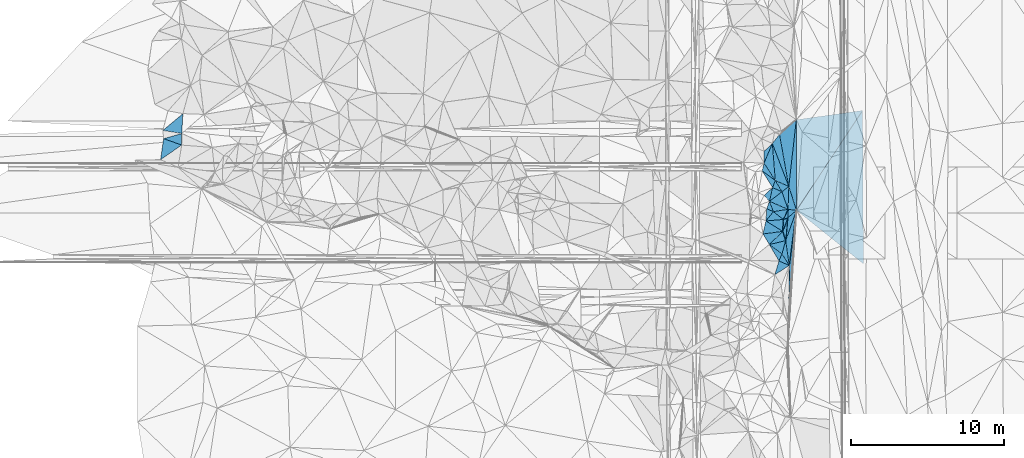
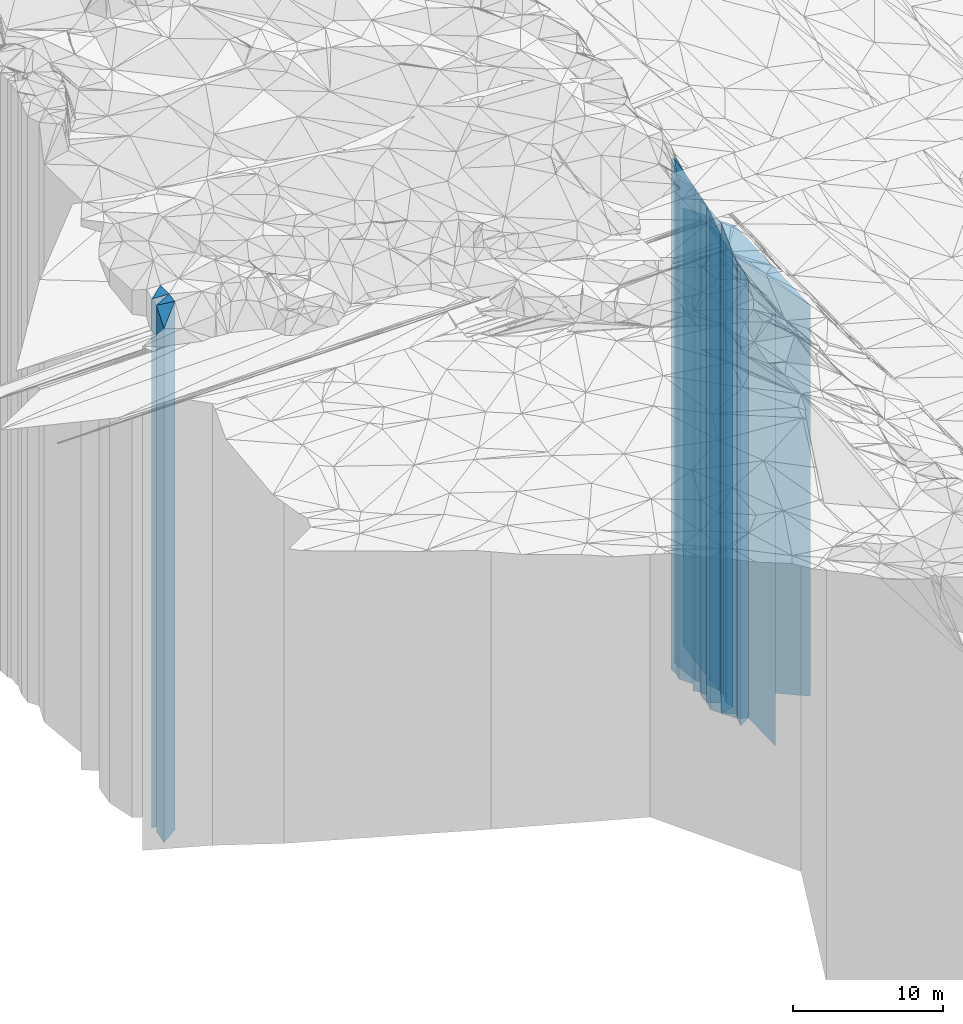
# One storey, part 214 of 275: 41 plates.
"""IFC2X3 building model written with IfcOpenShell, lengths in millimetres."""

import ifcopenshell
import ifcopenshell.guid

model = None  # the IFC model being written
_history = None  # IfcOwnerHistory: only IFC2X3 demands one
_inside = {}  # id of a spatial element -> (the spatial element, [elements in it])
_under = {}  # id of a project, library or spatial element -> (it, [spatial elements below it])
_declared = {}  # id of a project -> (the project, [libraries it declares])
_typed = {}  # id of a type object -> (the type object, [elements of that type])
_made_of = {}  # id of a material, layer set ... -> (it, [elements and type objects made of it])


def new_model(schema):
    """Start an empty IFC model of exactly this schema.

    Asked for "IFC4X3", IfcOpenShell would pick the latest addendum, in which some entities
    have other attributes; the version numbers below select the first issue.
    IFC2X3 requires an IfcOwnerHistory on every rooted entity: one is made here for all.
    """
    global model, _history
    if schema == "IFC4X3":
        model = ifcopenshell.file(schema_version=(4, 3, 0, 0))
    else:
        model = ifcopenshell.file(schema=schema)
    _inside.clear()
    _under.clear()
    _declared.clear()
    _typed.clear()
    _made_of.clear()
    _history = None
    if model.schema == "IFC2X3":
        org = make("IfcOrganization", Name="unknown")
        user = make(
            "IfcPersonAndOrganization",
            ThePerson=make("IfcPerson", FamilyName="unknown"),
            TheOrganization=org,
        )
        app = make(
            "IfcApplication",
            ApplicationDeveloper=org,
            Version="unknown",
            ApplicationFullName="unknown",
            ApplicationIdentifier="unknown",
        )
        _history = make(
            "IfcOwnerHistory",
            OwningUser=user,
            OwningApplication=app,
            ChangeAction="ADDED",
            CreationDate=0,
        )
    return model


def make(cls, **values):
    """One entity of the class cls with the attributes given. An attribute that is None is left unset."""
    return model.create_entity(
        cls, **{name: value for name, value in values.items() if value is not None}
    )


def rooted(cls, **values):
    """An entity with a GlobalId (a new one), such as an element, a storey or a relation."""
    return make(cls, GlobalId=ifcopenshell.guid.new(), OwnerHistory=_history, **values)


def si_unit(unit_type, name, prefix=None):
    """IfcSIUnit, for example si_unit("LENGTHUNIT", "METRE", prefix="MILLI")."""
    return make("IfcSIUnit", UnitType=unit_type, Prefix=prefix, Name=name)


def assignment(units):
    """IfcUnitAssignment: the units of a project."""
    return None if units is None else make("IfcUnitAssignment", Units=units)


def point(xyz):
    """IfcCartesianPoint."""
    return None if xyz is None else make("IfcCartesianPoint", Coordinates=xyz)


def direction(xyz):
    """IfcDirection."""
    return None if xyz is None else make("IfcDirection", DirectionRatios=xyz)


def frame(location, z_axis=None, x_axis=None):
    """IfcAxis2Placement3D, a coordinate frame: its origin and axes. An axis left out is left unset."""
    return make(
        "IfcAxis2Placement3D",
        Location=point(location),
        Axis=direction(z_axis),
        RefDirection=direction(x_axis),
    )


def origin_with_axes():
    """The frame at (0, 0, 0) with the z axis (0, 0, 1) and the x axis (1, 0, 0) written out."""
    return frame((0.0, 0.0, 0.0), z_axis=(0.0, 0.0, 1.0), x_axis=(1.0, 0.0, 0.0))


def place(relative_to, where):
    """IfcLocalPlacement: puts the frame where relative to a parent placement (None: the world)."""
    return make(
        "IfcLocalPlacement", PlacementRelTo=relative_to, RelativePlacement=where
    )


def context(
    kind, dimensions, precision=None, world=None, true_north=None, identifier=None
):
    """IfcGeometricRepresentationContext, for example the 3D "Model" context."""
    return make(
        "IfcGeometricRepresentationContext",
        ContextIdentifier=identifier,
        ContextType=kind,
        CoordinateSpaceDimension=dimensions,
        Precision=precision,
        WorldCoordinateSystem=world,
        TrueNorth=true_north,
    )


def subcontext(parent, identifier, kind, view, scale=None):
    """IfcGeometricRepresentationSubContext, for example "Body" below "Model"."""
    return make(
        "IfcGeometricRepresentationSubContext",
        ContextIdentifier=identifier,
        ContextType=kind,
        ParentContext=parent,
        TargetScale=scale,
        TargetView=view,
    )


def project(units=None, contexts=None):
    """IfcProject with its units and contexts."""
    return rooted(
        "IfcProject",
        Name="project",
        RepresentationContexts=contexts,
        UnitsInContext=assignment(units),
    )


def spatial(cls, under=None, at=None, **own):
    """A site, building, storey or space (cls), placed at a placement, below another one or the project."""
    s = rooted(cls, ObjectPlacement=at, **own)
    if under is not None:
        _under.setdefault(under.id(), (under, []))[1].append(s)
    return s


def faces_of(points, faces, orient=None, outer=None):
    """IfcFace entities. A face is a list of loops; a loop is a list of indices into points, from 0.

    orient and outer hold one flag for each loop. By default every Orientation is true, the
    first loop of a face is its IfcFaceOuterBound and the others are IfcFaceBound.
    """
    made = []
    for i, loops in enumerate(faces):
        bounds = []
        for j, loop in enumerate(loops):
            is_outer = j == 0 if outer is None else outer[i][j]
            bounds.append(
                make(
                    "IfcFaceOuterBound" if is_outer else "IfcFaceBound",
                    Bound=make("IfcPolyLoop", Polygon=[points[k] for k in loop]),
                    Orientation=True if orient is None else orient[i][j],
                )
            )
        made.append(make("IfcFace", Bounds=bounds))
    return made


def faceted_brep(points, faces, orient=None, outer=None, voids=None):
    """IfcFacetedBrep: a solid bounded by flat faces; with voids (closed shells), ...WithVoids."""
    shared = [point(p) for p in points]
    hull = make("IfcClosedShell", CfsFaces=faces_of(shared, faces, orient, outer))
    if voids is None:
        return make("IfcFacetedBrep", Outer=hull)
    return make(
        "IfcFacetedBrepWithVoids",
        Outer=hull,
        Voids=[
            make(cls, CfsFaces=faces_of(shared, fs, o, b)) for cls, fs, o, b in voids
        ],
    )


def shape(context_of_items, identifier, shape_type, items):
    """IfcShapeRepresentation: the items that make up one representation, for example the "Body"."""
    return make(
        "IfcShapeRepresentation",
        ContextOfItems=context_of_items,
        RepresentationIdentifier=identifier,
        RepresentationType=shape_type,
        Items=items,
    )


def material(Name=None, Category=None):
    """IfcMaterial."""
    return make("IfcMaterial", Name=Name, Category=Category)


def made_of(thing, what):
    """Note that an element or type object is made of a material, layer set ...; save() writes the relation."""
    if what is not None:
        _made_of.setdefault(what.id(), (what, []))[1].append(thing)
    return thing


def type_object(cls, material=None, **own):
    """A type object (cls), such as IfcWallType, which elements share."""
    return made_of(rooted(cls, **own), material)


def element(
    cls,
    number,
    at=None,
    inside=None,
    cuts=None,
    type_object=None,
    material=None,
    context=None,
    identifier="Body",
    shape_type=None,
    held_by="IfcProductDefinitionShape",
    body=None,
    shapes=None,
    **own,
):
    """One element of the class cls, such as IfcWall. Its Tag is "e" and its number.

    at: its placement. inside: the storey or other place that contains it. cuts: it is an
    opening in that element (IfcRelVoidsElement). A single representation is given by context,
    identifier, shape_type and body (its items); several are given by shapes. held_by: the class
    of the entity that holds the representations. save() writes the other relations.
    """
    e = rooted(cls, Tag="e%d" % number, ObjectPlacement=at, **own)
    if body is not None:
        shapes = [shape(context, identifier, shape_type, body)]
    if shapes is not None:
        e.Representation = make(held_by, Representations=shapes)
    if inside is not None:
        _inside.setdefault(inside.id(), (inside, []))[1].append(e)
    if cuts is not None:
        rooted(
            "IfcRelVoidsElement", RelatingBuildingElement=cuts, RelatedOpeningElement=e
        )
    if type_object is not None:
        _typed.setdefault(type_object.id(), (type_object, []))[1].append(e)
    return made_of(e, material)


def aggregate(whole, parts):
    """IfcRelAggregates: a whole, such as a stair, and the parts it consists of."""
    return rooted("IfcRelAggregates", RelatingObject=whole, RelatedObjects=parts)


def save(model, path):
    """Write the relations noted so far, then the file.

    IfcRelAggregates (storeys below a building ...), IfcRelContainedInSpatialStructure (elements
    in a storey), IfcRelDefinesByType, IfcRelAssociatesMaterial and IfcRelDeclares: one each for
    every whole, place, type object, material and project.
    """
    for whole, parts in _under.values():
        aggregate(whole, parts)
    for where, things in _inside.values():
        rooted(
            "IfcRelContainedInSpatialStructure",
            RelatedElements=things,
            RelatingStructure=where,
        )
    for kind, things in _typed.values():
        rooted("IfcRelDefinesByType", RelatedObjects=things, RelatingType=kind)
    for what, things in _made_of.values():
        rooted("IfcRelAssociatesMaterial", RelatedObjects=things, RelatingMaterial=what)
    for by, libraries in _declared.values():
        rooted("IfcRelDeclares", RelatingContext=by, RelatedDefinitions=libraries)
    model.write(path)


model = new_model("IFC2X3")

# Units and contexts
model_context = context("Model", 3, precision=1e-05, world=origin_with_axes())
body_context = subcontext(model_context, "Body", "Model", "MODEL_VIEW")
ifc_project = project(units=[si_unit("LENGTHUNIT", "METRE", prefix="MILLI"), si_unit("AREAUNIT", "SQUARE_METRE"), si_unit("VOLUMEUNIT", "CUBIC_METRE"), si_unit("MASSUNIT", "GRAM", prefix="KILO"), si_unit("TIMEUNIT", "SECOND"), si_unit("PLANEANGLEUNIT", "RADIAN"), si_unit("SOLIDANGLEUNIT", "STERADIAN"), si_unit("THERMODYNAMICTEMPERATUREUNIT", "DEGREE_CELSIUS"), si_unit("LUMINOUSINTENSITYUNIT", "LUMEN")], contexts=[model_context])

# Site, building, storey
site_placement = place(None, origin_with_axes())
site = spatial("IfcSite", under=ifc_project, at=site_placement, CompositionType="ELEMENT")
building_placement = place(site_placement, origin_with_axes())
building = spatial("IfcBuilding", under=site, at=building_placement, Name="Undefined", CompositionType="ELEMENT")
storey_placement = place(building_placement, origin_with_axes())
storey = spatial("IfcBuildingStorey", under=building, at=storey_placement, Name="Undefined", CompositionType="ELEMENT", Elevation=0.0)

# Plates
ifc_material = material()
plate_type_1 = type_object("IfcPlateType", PredefinedType="NOTDEFINED")
plate_1_placement = place(storey_placement, frame((-92905.7018994495, 69988.4205034706, 24010.5), z_axis=(0.139414385069645, -0.990234128494697, 0.0), x_axis=(-0.990234128494697, -0.139414385069646, 0.0)))
element("IfcPlate", 1, at=plate_1_placement, inside=storey, type_object=plate_type_1, material=ifc_material, Name="00", context=body_context, shape_type="Brep", body=[
    faceted_brep([(0.0, -16182.5, -2.91038304567337e-11), (5193.21240234376, -19493.5, 5869.29199218749), (5193.21240234376, 16182.5, 5869.29199218749), (-1.45519152283669e-11, 16182.5, 3.63797880709171e-12), (4378.23828125, -19493.5, 1.93831510841846e-08), (4378.23828125, 16182.5, 1.93831510841846e-08)], [[[0, 1, 2, 3]], [[1, 4, 5, 2]], [[4, 0, 3, 5]], [[5, 3, 2]], [[4, 1, 0]]]),
])
plate_type_2 = type_object("IfcPlateType", PredefinedType="NOTDEFINED")
plate_2_placement = place(storey_placement, frame((-138595.106650195, 68143.1824368439, 28804.0), z_axis=(0.989678188552629, -0.143307651935223, 0.0), x_axis=(-0.143307651935225, -0.989678188552629, 0.0)))
element("IfcPlate", 2, at=plate_2_placement, inside=storey, type_object=plate_type_2, material=ifc_material, Name="00", context=body_context, shape_type="Brep", body=[
    faceted_brep([(7.27595761418343e-12, -21976.0, -2.91038304567337e-11), (245.110916137688, -22146.0, 1227.85205078125), (245.110916137688, 20976.0, 1227.85205078125), (7.27595761418343e-12, 20976.0, -2.91038304567337e-11), (1392.83886718749, -20976.0, -6.92671164870262e-09), (1392.83886718749, 20976.0, -6.92671164870262e-09)], [[[0, 1, 2, 3]], [[1, 4, 5, 2]], [[4, 0, 3, 5]], [[5, 3, 2]], [[4, 1, 0]]]),
])
plate_type_3 = type_object("IfcPlateType", PredefinedType="NOTDEFINED")
plate_3_placement = place(storey_placement, frame((-137410.566962769, 68481.0666313719, 29404.0), z_axis=(-0.998335284083489, 0.0576772100048178, 0.0), x_axis=(0.0576772100048214, 0.998335284083489, 0.0)))
element("IfcPlate", 3, at=plate_3_placement, inside=storey, type_object=plate_type_3, material=ifc_material, Name="00", context=body_context, shape_type="Brep", body=[
    faceted_brep([(1.45519152283669e-11, -21686.0, 0.0), (125.723693847671, -21576.0, 1244.62585449219), (125.723693847671, 21576.0, 1244.62585449219), (1.45519152283669e-11, 21576.0, 0.0), (1292.51696777345, -21596.0, -3.87080945074558e-09), (1292.51696777345, 21576.0, -3.87080945074558e-09)], [[[0, 1, 2, 3]], [[1, 4, 5, 2]], [[4, 0, 3, 5]], [[5, 3, 2]], [[4, 1, 0]]]),
])
plate_type_4 = type_object("IfcPlateType", PredefinedType="NOTDEFINED")
plate_4_placement = place(storey_placement, frame((-138595.106650195, 68143.1824368439, 29304.0), z_axis=(0.334277440154242, 0.942474717434864, 0.0), x_axis=(0.942474717434867, -0.334277440154235, 0.0)))
element("IfcPlate", 4, at=plate_4_placement, inside=storey, type_object=plate_type_4, material=ifc_material, Name="00", context=body_context, shape_type="Brep", body=[
    faceted_brep([(0.0, -21476.0, 0.0), (1003.45166015625, -21786.0, 714.412231445313), (1003.45166015625, 21476.0, 714.412231445313), (0.0, 21476.0, 0.0), (1252.07824707031, -21646.0, -6.35191099718213e-09), (1252.07824707031, 21476.0, -6.35191099718213e-09)], [[[0, 1, 2, 3]], [[1, 4, 5, 2]], [[4, 0, 3, 5]], [[5, 3, 2]], [[4, 1, 0]]]),
])
plate_type_5 = type_object("IfcPlateType", PredefinedType="NOTDEFINED")
plate_5_placement = place(storey_placement, frame((-97732.2833530181, 65021.2964389774, 25666.0), z_axis=(-0.993706764242904, 0.112012797027383, 0.0), x_axis=(0.112012797027379, 0.993706764242904, 0.0)))
element("IfcPlate", 5, at=plate_5_placement, inside=storey, type_object=plate_type_5, material=ifc_material, Name="00", context=body_context, shape_type="Brep", body=[
    faceted_brep([(0.0, -19984.0, 2.91038304567337e-11), (3306.35058593749, -22944.0, 981.297851562515), (3306.35058593749, 17838.0, 981.297851562515), (-7.27595761418343e-12, 17838.0, -1.45519152283669e-11), (4384.326171875, -17838.0, 1.84663804247975e-08), (4384.326171875, 17838.0, 1.84663804247975e-08)], [[[0, 1, 2, 3]], [[1, 4, 5, 2]], [[4, 0, 3, 5]], [[5, 3, 2]], [[4, 1, 0]]]),
])
plate_type_6 = type_object("IfcPlateType", PredefinedType="NOTDEFINED")
plate_6_placement = place(storey_placement, frame((-98613.8842218023, 65407.7934094169, 26739.0), z_axis=(0.401513309984556, 0.915853187964777, 0.0), x_axis=(0.915853187964776, -0.401513309984559, 0.0)))
element("IfcPlate", 6, at=plate_6_placement, inside=storey, type_object=plate_type_6, material=ifc_material, Name="00", context=body_context, shape_type="Brep", body=[
    faceted_brep([(0.0, -21301.0, -4.54747350886464e-12), (-1148.86682128906, -22321.0, 2136.39990234376), (-1148.86682128906, 18911.0, 2136.39990234376), (0.0, 18911.0, 0.0), (962.600646972656, -18911.0, 5.74800651520491e-10), (962.600646972656, 18911.0, 5.74800651520491e-10)], [[[0, 1, 2, 3]], [[1, 4, 5, 2]], [[4, 0, 3, 5]], [[5, 3, 2]], [[4, 1, 0]]]),
])
plate_type_7 = type_object("IfcPlateType", PredefinedType="NOTDEFINED")
plate_7_placement = place(storey_placement, frame((-98337.0520925166, 68416.7573460893, 26739.0), z_axis=(0.781905014914304, -0.623397583931685, 0.0), x_axis=(-0.623397583931673, -0.781905014914314, 0.0)))
element("IfcPlate", 7, at=plate_7_placement, inside=storey, type_object=plate_type_7, material=ifc_material, Name="00", context=body_context, shape_type="Brep", body=[
    faceted_brep([(-1.2732925824821e-11, -21871.0, 0.0), (2277.91650390621, -18911.0, 2589.59375), (2277.91650390621, 18911.0, 2589.59375), (0.0, 18911.0, 0.0), (755.910034179688, -22321.0, 2.91038304567337e-10), (755.910034179688, 18911.0, 2.91038304567337e-10)], [[[0, 1, 2, 3]], [[1, 4, 5, 2]], [[4, 0, 3, 5]], [[5, 3, 2]], [[4, 1, 0]]]),
])
plate_type_8 = type_object("IfcPlateType", PredefinedType="NOTDEFINED")
plate_8_placement = place(storey_placement, frame((-99347.8378395339, 66548.4125776842, 27934.0), z_axis=(0.840944164836263, 0.541121900894651, 0.0), x_axis=(0.54112190089464, -0.84094416483627, 0.0)))
element("IfcPlate", 8, at=plate_8_placement, inside=storey, type_object=plate_type_8, material=ifc_material, Name="00", context=body_context, shape_type="Brep", body=[
    faceted_brep([(1.45519152283669e-11, -20806.0, 2.18278728425503e-11), (-782.16961669919, -21126.0, 1144.90637207033), (-782.16961669919, 20106.0, 1144.90637207033), (1.45519152283669e-11, 20106.0, 2.18278728425503e-11), (1356.35546875, -20106.0, 6.30825525149703e-09), (1356.35546875, 20106.0, 6.30825525149703e-09)], [[[0, 1, 2, 3]], [[1, 4, 5, 2]], [[4, 0, 3, 5]], [[5, 3, 2]], [[4, 1, 0]]]),
])
plate_type_9 = type_object("IfcPlateType", PredefinedType="NOTDEFINED")
plate_9_placement = place(storey_placement, frame((-98792.4498808621, 64946.150359643, 27934.0), z_axis=(-0.932659802744667, 0.360757109901216, 0.0), x_axis=(0.360757109901238, 0.932659802744659, 0.0)))
element("IfcPlate", 9, at=plate_9_placement, inside=storey, type_object=plate_type_9, material=ifc_material, Name="00", context=body_context, shape_type="Brep", body=[
    faceted_brep([(0.0, -20126.0, 0.0), (770.746398925803, -20726.0, 1025.30480957033), (770.746398925803, 20106.0, 1025.30480957033), (1.45519152283669e-11, 20106.0, 2.18278728425503e-11), (494.974761962891, -20106.0, -1.92085281014442e-09), (494.974761962891, 20106.0, -1.92085281014442e-09)], [[[0, 1, 2, 3]], [[1, 4, 5, 2]], [[4, 0, 3, 5]], [[5, 3, 2]], [[4, 1, 0]]]),
])
plate_type_10 = type_object("IfcPlateType", PredefinedType="NOTDEFINED")
plate_10_placement = place(storey_placement, frame((-99347.8378395339, 66548.4125776842, 27934.0), z_axis=(0.972570637953988, -0.232607725988996, 0.0), x_axis=(-0.232607725988999, -0.972570637953988, 0.0)))
element("IfcPlate", 10, at=plate_10_placement, inside=storey, type_object=plate_type_10, material=ifc_material, Name="00", context=body_context, shape_type="Brep", body=[
    faceted_brep([(1.45519152283669e-11, -20806.0, 2.18278728425503e-11), (938.609436035171, -20106.0, 979.138549804702), (938.609436035171, 20106.0, 979.138549804702), (1.45519152283669e-11, 20106.0, 2.18278728425503e-11), (528.01513671875, -20726.0, -1.28056854009628e-09), (528.01513671875, 20106.0, -1.28056854009628e-09)], [[[0, 1, 2, 3]], [[1, 4, 5, 2]], [[4, 0, 3, 5]], [[5, 3, 2]], [[4, 1, 0]]]),
])
plate_type_11 = type_object("IfcPlateType", PredefinedType="NOTDEFINED")
plate_11_placement = place(storey_placement, frame((-97780.8279005577, 63523.7506377065, 25666.0), z_axis=(0.128376642995731, 0.991725484967058, 0.0), x_axis=(0.991725484967057, -0.12837664299574, 0.0)))
element("IfcPlate", 11, at=plate_11_placement, inside=storey, type_object=plate_type_11, material=ifc_material, Name="00", context=body_context, shape_type="Brep", body=[
    faceted_brep([(0.0, -19624.0, 0.0), (-144.107040405259, -19984.0, 1491.38635253906), (-144.107040405259, 17838.0, 1491.38635253906), (-7.27595761418343e-12, 17838.0, -1.45519152283669e-11), (555.489868164048, -17838.0, -1.36788003146648e-09), (555.489868164048, 17838.0, -1.36788003146648e-09)], [[[0, 1, 2, 3]], [[1, 4, 5, 2]], [[4, 0, 3, 5]], [[5, 3, 2]], [[4, 1, 0]]]),
])
plate_type_12 = type_object("IfcPlateType", PredefinedType="NOTDEFINED")
plate_12_placement = place(storey_placement, frame((-97732.2833530181, 65021.2964389774, 25666.0), z_axis=(0.952368722855946, 0.304948873953873, 0.0), x_axis=(0.304948873953878, -0.952368722855944, 0.0)))
element("IfcPlate", 12, at=plate_12_placement, inside=storey, type_object=plate_type_12, material=ifc_material, Name="00", context=body_context, shape_type="Brep", body=[
    faceted_brep([(0.0, -19984.0, 2.91038304567337e-11), (-3999.45727539063, -17838.0, 1796.29028320313), (-3999.45727539063, 17838.0, 1796.29028320313), (-7.27595761418343e-12, 17838.0, -1.45519152283669e-11), (1647.32177734375, -17838.0, -5.36965671926737e-09), (1647.32177734375, 17838.0, -5.36965671926737e-09)], [[[0, 1, 2, 3]], [[1, 4, 5, 2]], [[4, 0, 3, 5]], [[5, 3, 2]], [[4, 1, 0]]]),
])
plate_type_13 = type_object("IfcPlateType", PredefinedType="NOTDEFINED")
plate_13_placement = place(storey_placement, frame((-98613.8842218023, 65407.7934094169, 27414.0), z_axis=(0.932659802744688, -0.360757109901163, 0.0), x_axis=(-0.360757109901238, -0.932659802744659, 0.0)))
element("IfcPlate", 13, at=plate_13_placement, inside=storey, type_object=plate_type_13, material=ifc_material, Name="00", context=body_context, shape_type="Brep", body=[
    faceted_brep([(-7.27595761418343e-12, -20626.0, 0.0), (530.330078125, -19586.0, 671.75146484375), (530.330078125, 19586.0, 671.75146484375), (-7.27595761418343e-12, 19586.0, 0.0), (494.974761962876, -20646.0, -1.94995664060116e-09), (494.974761962876, 19586.0, -1.94995664060116e-09)], [[[0, 1, 2, 3]], [[1, 4, 5, 2]], [[4, 0, 3, 5]], [[5, 3, 2]], [[4, 1, 0]]]),
])
plate_type_14 = type_object("IfcPlateType", PredefinedType="NOTDEFINED")
plate_14_placement = place(storey_placement, frame((-98996.2177676192, 64046.940346172, 27414.0), z_axis=(-0.606668938331786, 0.794954589434757, 0.0), x_axis=(0.794954589434756, 0.606668938331787, 0.0)))
element("IfcPlate", 14, at=plate_14_placement, inside=storey, type_object=plate_type_14, material=ifc_material, Name="00", context=body_context, shape_type="Brep", body=[
    faceted_brep([(-7.27595761418343e-12, -20556.0, 0.0), (707.508972167983, -20646.0, 591.211486816377), (707.508972167983, 19586.0, 591.211486816377), (-7.27595761418343e-12, 19586.0, 0.0), (1028.39685058594, -19586.0, -1.60071067512035e-09), (1028.39685058594, 19586.0, -1.60071067512035e-09)], [[[0, 1, 2, 3]], [[1, 4, 5, 2]], [[4, 0, 3, 5]], [[5, 3, 2]], [[4, 1, 0]]]),
])
plate_type_15 = type_object("IfcPlateType", PredefinedType="NOTDEFINED")
plate_15_placement = place(storey_placement, frame((-98808.2845899003, 67825.7074891318, 28284.0), z_axis=(0.688444761873534, -0.725288776866768, 0.0), x_axis=(-0.725288776866784, -0.688444761873517, 0.0)))
element("IfcPlate", 15, at=plate_15_placement, inside=storey, type_object=plate_type_15, material=ifc_material, Name="00", context=body_context, shape_type="Brep", body=[
    faceted_brep([(-2.18278728425503e-11, -20776.0, 0.0), (1270.6789550781, -20456.0, 554.955078125), (1270.6789550781, 20456.0, 554.955078125), (1.45519152283669e-11, 20456.0, 0.0), (743.303466796846, -21166.0, 1.16415321826935e-10), (743.303466796846, 20456.0, 1.16415321826935e-10)], [[[0, 1, 2, 3]], [[1, 4, 5, 2]], [[4, 0, 3, 5]], [[5, 3, 2]], [[4, 1, 0]]]),
])
plate_type_16 = type_object("IfcPlateType", PredefinedType="NOTDEFINED")
plate_16_placement = place(storey_placement, frame((-98996.2177676192, 64046.940346172, 26559.0), z_axis=(0.395392585829159, 0.918512222603124, 0.0), x_axis=(0.918512222603125, -0.395392585829156, 0.0)))
element("IfcPlate", 16, at=plate_16_placement, inside=storey, type_object=plate_type_16, material=ifc_material, Name="00", context=body_context, shape_type="Brep", body=[
    faceted_brep([(0.0, -21411.0, -7.27595761418343e-12), (504.226165771455, -20441.0, 896.30126953125), (504.226165771455, 18731.0, 896.30126953125), (-2.91038304567337e-11, 18731.0, -7.27595761418343e-12), (1323.21582031249, -18731.0, -8.37462721392512e-09), (1323.21582031249, 18731.0, -8.37462721392512e-09)], [[[0, 1, 2, 3]], [[1, 4, 5, 2]], [[4, 0, 3, 5]], [[5, 3, 2]], [[4, 1, 0]]]),
])
plate_type_17 = type_object("IfcPlateType", PredefinedType="NOTDEFINED")
plate_17_placement = place(storey_placement, frame((-98613.8842218023, 65407.7934094169, 26739.0), z_axis=(0.861069357856539, 0.508487522915289, 0.0), x_axis=(0.508487522915283, -0.861069357856543, 0.0)))
element("IfcPlate", 17, at=plate_17_placement, inside=storey, type_object=plate_type_17, material=ifc_material, Name="00", context=body_context, shape_type="Brep", body=[
    faceted_brep([(0.0, -21301.0, -4.54747350886464e-12), (781.08374023439, -18911.0, 562.590637207024), (781.08374023439, 18911.0, 562.590637207024), (0.0, 18911.0, 0.0), (855.862121582031, -20261.0, -1.60071067512035e-09), (855.862121582031, 18911.0, -1.60071067512035e-09)], [[[0, 1, 2, 3]], [[1, 4, 5, 2]], [[4, 0, 3, 5]], [[5, 3, 2]], [[4, 1, 0]]]),
])
plate_type_18 = type_object("IfcPlateType", PredefinedType="NOTDEFINED")
plate_18_placement = place(storey_placement, frame((-97780.8279005577, 63523.7506377065, 26559.0), z_axis=(-0.395392585829159, -0.918512222603124, 0.0), x_axis=(-0.918512222603125, 0.395392585829157, 0.0)))
element("IfcPlate", 18, at=plate_18_placement, inside=storey, type_object=plate_type_18, material=ifc_material, Name="00", context=body_context, shape_type="Brep", body=[
    faceted_brep([(0.0, -18731.0, 0.0), (822.617126464829, -21121.0, 519.038574218743), (822.617126464829, 18731.0, 519.038574218743), (-2.91038304567337e-11, 18731.0, -7.27595761418343e-12), (1323.2158203125, -21411.0, -8.38190317153931e-09), (1323.21582031249, 18731.0, -8.37462721392512e-09)], [[[0, 1, 2, 3]], [[1, 4, 5, 2]], [[4, 0, 3, 5]], [[5, 3, 2]], [[4, 1, 0]]]),
])
plate_type_19 = type_object("IfcPlateType", PredefinedType="NOTDEFINED")
plate_19_placement = place(storey_placement, frame((-97798.1298930763, 62969.4035974376, 25666.0), z_axis=(-0.647702113842908, 0.761893674815212, 0.0), x_axis=(0.761893674815213, 0.647702113842908, 0.0)))
element("IfcPlate", 19, at=plate_19_placement, inside=storey, type_object=plate_type_19, material=ifc_material, Name="00", context=body_context, shape_type="Brep", body=[
    faceted_brep([(7.27595761418343e-12, -19274.0, 1.45519152283669e-11), (372.234039306648, -19624.0, 411.146972656265), (372.234039306648, 17838.0, 411.146972656265), (-7.27595761418343e-12, 17838.0, -1.45519152283669e-11), (745.767395019539, -17838.0, -7.13043846189976e-10), (745.767395019539, 17838.0, -7.13043846189976e-10)], [[[0, 1, 2, 3]], [[1, 4, 5, 2]], [[4, 0, 3, 5]], [[5, 3, 2]], [[4, 1, 0]]]),
])
plate_type_20 = type_object("IfcPlateType", PredefinedType="NOTDEFINED")
plate_20_placement = place(storey_placement, frame((-98792.4498808621, 64946.150359643, 27899.0), z_axis=(0.685197132232283, -0.728357666246917, 0.0), x_axis=(-0.728357666246916, -0.685197132232284, 0.0)))
element("IfcPlate", 20, at=plate_20_placement, inside=storey, type_object=plate_type_20, material=ifc_material, Name="00", context=body_context, shape_type="Brep", body=[
    faceted_brep([(-3.63797880709171e-12, -20161.0, 0.0), (764.552001953114, -20071.0, 515.325317382813), (764.552001953114, 20071.0, 515.325317382813), (-7.27595761418343e-12, 20071.0, 0.0), (752.728393554684, -20541.0, -2.05182004719973e-09), (752.728393554684, 20071.0, -2.05182004719973e-09)], [[[0, 1, 2, 3]], [[1, 4, 5, 2]], [[4, 0, 3, 5]], [[5, 3, 2]], [[4, 1, 0]]]),
])
plate_type_21 = type_object("IfcPlateType", PredefinedType="NOTDEFINED")
plate_21_placement = place(storey_placement, frame((-97732.2833530181, 65021.2964389774, 26559.0), z_axis=(0.617508175904844, -0.786564461878791, 0.0), x_axis=(-0.786564461878791, -0.617508175904844, 0.0)))
element("IfcPlate", 21, at=plate_21_placement, inside=storey, type_object=plate_type_21, material=ifc_material, Name="00", context=body_context, shape_type="Brep", body=[
    faceted_brep([(-1.45519152283669e-11, -19091.0, 0.0), (962.930175781257, -18731.0, 1147.93969726563), (962.930175781257, 18731.0, 1147.93969726563), (-2.91038304567337e-11, 18731.0, -7.27595761418343e-12), (567.53857421875, -20441.0, 2.64844857156277e-09), (567.53857421875, 18731.0, 2.64844857156277e-09)], [[[0, 1, 2, 3]], [[1, 4, 5, 2]], [[4, 0, 3, 5]], [[5, 3, 2]], [[4, 1, 0]]]),
])
plate_type_22 = type_object("IfcPlateType", PredefinedType="NOTDEFINED")
plate_22_placement = place(storey_placement, frame((-99227.116018301, 62763.980487941, 27754.0), z_axis=(-0.781587015067835, 0.623796231054142, 0.0), x_axis=(0.623796231054141, 0.781587015067835, 0.0)))
element("IfcPlate", 22, at=plate_22_placement, inside=storey, type_object=plate_type_22, material=ifc_material, Name="00", context=body_context, shape_type="Brep", body=[
    faceted_brep([(5.45696821063757e-12, -20346.0, 0.0), (656.458251953123, -20726.0, 458.325805664063), (656.458251953123, 19926.0, 458.325805664063), (5.45696821063757e-12, 19926.0, 0.0), (778.267333984373, -19926.0, 9.60426405072212e-10), (778.267333984373, 19926.0, 9.60426405072212e-10)], [[[0, 1, 2, 3]], [[1, 4, 5, 2]], [[4, 0, 3, 5]], [[5, 3, 2]], [[4, 1, 0]]]),
])
plate_type_23 = type_object("IfcPlateType", PredefinedType="NOTDEFINED")
plate_23_placement = place(storey_placement, frame((-98089.7388181516, 62862.3324303737, 26384.0), z_axis=(-0.344674282034968, 0.938722344095249, 0.0), x_axis=(0.938722344095242, 0.344674282034987, 0.0)))
element("IfcPlate", 23, at=plate_23_placement, inside=storey, type_object=plate_type_23, material=ifc_material, Name="00", context=body_context, shape_type="Brep", body=[
    faceted_brep([(0.0, -19096.0, 0.0), (517.955444335923, -18906.0, 514.414428710981), (517.955444335923, 18556.0, 514.414428710981), (0.0, 18556.0, 2.91038304567337e-11), (310.644500732407, -18556.0, -8.73114913702011e-10), (310.644500732407, 18556.0, -8.73114913702011e-10)], [[[0, 1, 2, 3]], [[1, 4, 5, 2]], [[4, 0, 3, 5]], [[5, 3, 2]], [[4, 1, 0]]]),
])
plate_type_24 = type_object("IfcPlateType", PredefinedType="NOTDEFINED")
plate_24_placement = place(storey_placement, frame((-98996.2177676192, 64046.940346172, 27754.0), z_axis=(0.937513721766151, -0.347948302913206, 0.0), x_axis=(-0.347948302913218, -0.937513721766147, 0.0)))
element("IfcPlate", 24, at=plate_24_placement, inside=storey, type_object=plate_type_24, material=ifc_material, Name="00", context=body_context, shape_type="Brep", body=[
    faceted_brep([(0.0, -20216.0, 0.0), (543.936889648438, -19926.0, 473.426544189468), (543.936889648438, 19926.0, 473.426544189468), (5.45696821063757e-12, 19926.0, 0.0), (516.236389160164, -20726.0, -2.12457962334156e-09), (516.236389160164, 19926.0, -2.12457962334156e-09)], [[[0, 1, 2, 3]], [[1, 4, 5, 2]], [[4, 0, 3, 5]], [[5, 3, 2]], [[4, 1, 0]]]),
])
plate_type_25 = type_object("IfcPlateType", PredefinedType="NOTDEFINED")
plate_25_placement = place(storey_placement, frame((-97780.8279005577, 63523.7506377065, 26559.0), z_axis=(0.155741908973287, -0.987797781830551, 0.0), x_axis=(-0.987797781830551, -0.155741908973286, 0.0)))
element("IfcPlate", 25, at=plate_25_placement, inside=storey, type_object=plate_type_25, material=ifc_material, Name="00", context=body_context, shape_type="Brep", body=[
    faceted_brep([(0.0, -18731.0, 0.0), (408.152038574233, -18921.0, 605.237060546875), (408.152038574233, 18731.0, 605.237060546875), (-2.91038304567337e-11, 18731.0, -7.27595761418343e-12), (972.676696777358, -21121.0, 2.08092387765646e-09), (972.676696777358, 18731.0, 2.08092387765646e-09)], [[[0, 1, 2, 3]], [[1, 4, 5, 2]], [[4, 0, 3, 5]], [[5, 3, 2]], [[4, 1, 0]]]),
])
plate_type_26 = type_object("IfcPlateType", PredefinedType="NOTDEFINED")
plate_26_placement = place(storey_placement, frame((-97798.1298930763, 62969.4035974376, 26384.0), z_axis=(0.344674282034978, -0.938722344095245, 0.0), x_axis=(-0.938722344095247, -0.344674282034973, 0.0)))
element("IfcPlate", 26, at=plate_26_placement, inside=storey, type_object=plate_type_26, material=ifc_material, Name="00", context=body_context, shape_type="Brep", body=[
    faceted_brep([(0.0, -18556.0, -2.91038304567337e-11), (614.850769042983, -18976.0, 721.081542968721), (614.850769042983, 18556.0, 721.081542968721), (0.0, 18556.0, 2.91038304567337e-11), (310.644500732436, -19096.0, -9.16770659387112e-10), (310.644500732407, 18556.0, -8.73114913702011e-10)], [[[0, 1, 2, 3]], [[1, 4, 5, 2]], [[4, 0, 3, 5]], [[5, 3, 2]], [[4, 1, 0]]]),
])
plate_type_27 = type_object("IfcPlateType", PredefinedType="NOTDEFINED")
plate_27_placement = place(storey_placement, frame((-98089.7388181516, 62862.3324303737, 26594.0), z_axis=(0.0861510839925128, -0.996282083913444, 0.0), x_axis=(-0.996282083913444, -0.0861510839925146, 0.0)))
element("IfcPlate", 27, at=plate_27_placement, inside=storey, type_object=plate_type_27, material=ifc_material, Name="00", context=body_context, shape_type="Brep", body=[
    faceted_brep([(1.45519152283669e-11, -18886.0, -1.45519152283669e-11), (104.237686157241, -18766.0, 775.651000976548), (104.237686157241, 18766.0, 775.651000976548), (1.45519152283669e-11, 18766.0, -1.45519152283669e-11), (1141.62170410158, -21506.0, -1.60071067512035e-10), (1141.62170410158, 18766.0, -1.60071067512035e-10)], [[[0, 1, 2, 3]], [[1, 4, 5, 2]], [[4, 0, 3, 5]], [[5, 3, 2]], [[4, 1, 0]]]),
])
plate_type_28 = type_object("IfcPlateType", PredefinedType="NOTDEFINED")
plate_28_placement = place(storey_placement, frame((-99227.116018301, 62763.980487941, 26654.0), z_axis=(-0.0861510839925128, 0.996282083913444, 0.0), x_axis=(0.996282083913444, 0.0861510839925168, 0.0)))
element("IfcPlate", 28, at=plate_28_placement, inside=storey, type_object=plate_type_28, material=ifc_material, Name="00", context=body_context, shape_type="Brep", body=[
    faceted_brep([(-1.45519152283669e-11, -21446.0, 0.0), (536.079528808579, -21026.0, 564.197448730469), (536.079528808579, 18826.0, 564.197448730469), (-1.45519152283669e-11, 18826.0, -7.27595761418343e-12), (1141.62170410155, -18826.0, -1.45519152283669e-10), (1141.62170410155, 18826.0, -1.45519152283669e-10)], [[[0, 1, 2, 3]], [[1, 4, 5, 2]], [[4, 0, 3, 5]], [[5, 3, 2]], [[4, 1, 0]]]),
])
plate_type_29 = type_object("IfcPlateType", PredefinedType="NOTDEFINED")
plate_29_placement = place(storey_placement, frame((-99419.6222398632, 61913.4857174339, 26594.0), z_axis=(-0.128181942018144, 0.991750669140413, 0.0), x_axis=(0.991750669140413, 0.128181942018147, 0.0)))
element("IfcPlate", 29, at=plate_29_placement, inside=storey, type_object=plate_type_29, material=ifc_material, Name="00", context=body_context, shape_type="Brep", body=[
    faceted_brep([(1.45519152283669e-11, -22026.0, 0.0), (299.936248779282, -21506.0, 818.802917480469), (299.936248779282, 18766.0, 818.802917480469), (1.45519152283669e-11, 18766.0, -1.45519152283669e-11), (1303.61035156249, -18766.0, 4.11819200962782e-09), (1303.61035156249, 18766.0, 4.11819200962782e-09)], [[[0, 1, 2, 3]], [[1, 4, 5, 2]], [[4, 0, 3, 5]], [[5, 3, 2]], [[4, 1, 0]]]),
])
plate_type_30 = type_object("IfcPlateType", PredefinedType="NOTDEFINED")
plate_30_placement = place(storey_placement, frame((-97936.0170010948, 61476.0894491612, 25666.0), z_axis=(-0.941705149591094, 0.336439312853916, 0.0), x_axis=(0.336439312853913, 0.941705149591095, 0.0)))
element("IfcPlate", 30, at=plate_30_placement, inside=storey, type_object=plate_type_30, material=ifc_material, Name="00", context=body_context, shape_type="Brep", body=[
    faceted_brep([(0.0, -19034.0, 0.0), (1452.65222167969, -19274.0, 372.560577392593), (1452.65222167969, 17838.0, 372.560577392593), (-7.27595761418343e-12, 17838.0, -1.45519152283669e-11), (2098.69213867188, -17838.0, -1.13213900476694e-08), (2098.69213867188, 17838.0, -1.13213900476694e-08)], [[[0, 1, 2, 3]], [[1, 4, 5, 2]], [[4, 0, 3, 5]], [[5, 3, 2]], [[4, 1, 0]]]),
])
plate_type_31 = type_object("IfcPlateType", PredefinedType="NOTDEFINED")
plate_31_placement = place(storey_placement, frame((-99004.6468349279, 61222.258248869, 26264.0), z_axis=(-0.231099677077141, 0.972930079324738, 0.0), x_axis=(0.97293007932474, 0.231099677077134, 0.0)))
element("IfcPlate", 31, at=plate_31_placement, inside=storey, type_object=plate_type_31, material=ifc_material, Name="00", context=body_context, shape_type="Brep", body=[
    faceted_brep([(7.27595761418343e-12, -21536.0, 0.0), (1052.47595214844, -19096.0, 632.213928222642), (1052.47595214844, 18436.0, 632.213928222642), (0.0, 18436.0, -1.45519152283669e-11), (1098.36242675781, -18436.0, 3.62342689186335e-09), (1098.36242675781, 18436.0, 3.62342689186335e-09)], [[[0, 1, 2, 3]], [[1, 4, 5, 2]], [[4, 0, 3, 5]], [[5, 3, 2]], [[4, 1, 0]]]),
])
plate_type_32 = type_object("IfcPlateType", PredefinedType="NOTDEFINED")
plate_32_placement = place(storey_placement, frame((-97798.1298930763, 62969.4035974376, 26264.0), z_axis=(0.937939772097033, -0.346798189035879, 0.0), x_axis=(-0.346798189035872, -0.937939772097036, 0.0)))
element("IfcPlate", 32, at=plate_32_placement, inside=storey, type_object=plate_type_32, material=ifc_material, Name="00", context=body_context, shape_type="Brep", body=[
    faceted_brep([(-3.63797880709171e-12, -18676.0, -1.45519152283669e-11), (1448.45776367187, -18436.0, 388.548828124971), (1448.45776367187, 18436.0, 388.548828124971), (0.0, 18436.0, -1.45519152283669e-11), (947.628601074215, -19096.0, -2.11002770811319e-09), (947.628601074215, 18436.0, -2.11002770811319e-09)], [[[0, 1, 2, 3]], [[1, 4, 5, 2]], [[4, 0, 3, 5]], [[5, 3, 2]], [[4, 1, 0]]]),
])
plate_type_33 = type_object("IfcPlateType", PredefinedType="NOTDEFINED")
plate_33_placement = place(storey_placement, frame((-98126.7657818542, 62080.5850261829, 26594.0), z_axis=(0.128181942018144, -0.991750669140413, 0.0), x_axis=(-0.991750669140413, -0.128181942018147, 0.0)))
element("IfcPlate", 33, at=plate_33_placement, inside=storey, type_object=plate_type_33, material=ifc_material, Name="00", context=body_context, shape_type="Brep", body=[
    faceted_brep([(0.0, -18766.0, 0.0), (980.6611328125, -21206.0, 738.717651367188), (980.6611328125, 18766.0, 738.717651367188), (1.45519152283669e-11, 18766.0, -1.45519152283669e-11), (1303.6103515625, -22026.0, 4.11819200962782e-09), (1303.61035156249, 18766.0, 4.11819200962782e-09)], [[[0, 1, 2, 3]], [[1, 4, 5, 2]], [[4, 0, 3, 5]], [[5, 3, 2]], [[4, 1, 0]]]),
])
plate_type_34 = type_object("IfcPlateType", PredefinedType="NOTDEFINED")
plate_34_placement = place(storey_placement, frame((-97936.0170010948, 61476.0894491612, 26259.0), z_axis=(0.231099677077141, -0.972930079324738, 0.0), x_axis=(-0.97293007932474, -0.231099677077134, 0.0)))
element("IfcPlate", 34, at=plate_34_placement, inside=storey, type_object=plate_type_34, material=ifc_material, Name="00", context=body_context, shape_type="Brep", body=[
    faceted_brep([(-1.45519152283669e-11, -18441.0, 1.45519152283669e-11), (434.829162597642, -18431.0, 782.255432128921), (434.829162597642, 18431.0, 782.255432128921), (-1.45519152283669e-11, 18431.0, 1.45519152283669e-11), (1098.36242675781, -21541.0, 3.63797880709171e-09), (1098.36242675781, 18431.0, 3.63797880709171e-09)], [[[0, 1, 2, 3]], [[1, 4, 5, 2]], [[4, 0, 3, 5]], [[5, 3, 2]], [[4, 1, 0]]]),
])
plate_type_35 = type_object("IfcPlateType", PredefinedType="NOTDEFINED")
plate_35_placement = place(storey_placement, frame((-98375.1537153246, 60144.7897285065, 26259.0), z_axis=(-0.922283021491537, 0.386515236786909, 0.0), x_axis=(0.386515236786901, 0.922283021491541, 0.0)))
element("IfcPlate", 35, at=plate_35_placement, inside=storey, type_object=plate_type_35, material=ifc_material, Name="00", context=body_context, shape_type="Brep", body=[
    faceted_brep([(0.0, -18651.0, 0.0), (750.42224121093, -21541.0, 997.02880859375), (750.42224121093, 18431.0, 997.02880859375), (-1.45519152283669e-11, 18431.0, 1.45519152283669e-11), (509.313262939453, -18431.0, 9.60426405072212e-10), (509.313262939453, 18431.0, 9.60426405072212e-10)], [[[0, 1, 2, 3]], [[1, 4, 5, 2]], [[4, 0, 3, 5]], [[5, 3, 2]], [[4, 1, 0]]]),
])
plate_type_36 = type_object("IfcPlateType", PredefinedType="NOTDEFINED")
plate_36_placement = place(storey_placement, frame((-97699.4877933211, 59853.1125750592, 25666.0), z_axis=(-0.991597724405391, 0.129359781052884, 0.0), x_axis=(0.129359781052885, 0.991597724405391, 0.0)))
element("IfcPlate", 36, at=plate_36_placement, inside=storey, type_object=plate_type_36, material=ifc_material, Name="00", context=body_context, shape_type="Brep", body=[
    faceted_brep([(7.27595761418343e-12, -17914.0, -1.45519152283669e-11), (1578.74279785157, -19034.0, 444.48974609375), (1578.74279785157, 17838.0, 444.48974609375), (-7.27595761418343e-12, 17838.0, -1.45519152283669e-11), (3629.82495117188, -17838.0, 8.26548784971237e-09), (3629.82495117188, 17838.0, 8.26548784971237e-09)], [[[0, 1, 2, 3]], [[1, 4, 5, 2]], [[4, 0, 3, 5]], [[5, 3, 2]], [[4, 1, 0]]]),
])
plate_type_37 = type_object("IfcPlateType", PredefinedType="NOTDEFINED")
plate_37_placement = place(storey_placement, frame((-98178.2963788696, 60614.5207037294, 25704.0), z_axis=(0.922283021491537, -0.386515236786909, 0.0), x_axis=(-0.386515236786901, -0.922283021491541, 0.0)))
element("IfcPlate", 37, at=plate_37_placement, inside=storey, type_object=plate_type_37, material=ifc_material, Name="00", context=body_context, shape_type="Brep", body=[
    faceted_brep([(0.0, -18986.0, 1.45519152283669e-11), (517.1669921875, -17876.0, 735.892883300781), (517.1669921875, 17876.0, 735.892883300781), (0.0, 17876.0, 1.45519152283669e-11), (509.313262939453, -19206.0, 9.74978320300579e-10), (509.313262939453, 17876.0, 9.74978320300579e-10)], [[[0, 1, 2, 3]], [[1, 4, 5, 2]], [[4, 0, 3, 5]], [[5, 3, 2]], [[4, 1, 0]]]),
])
plate_type_38 = type_object("IfcPlateType", PredefinedType="NOTDEFINED")
plate_38_placement = place(storey_placement, frame((-98645.928522441, 59248.7534547814, 25704.0), z_axis=(-0.538192370792718, 0.842822028675398, 0.0), x_axis=(0.842822028675398, 0.538192370792717, 0.0)))
element("IfcPlate", 38, at=plate_38_placement, inside=storey, type_object=plate_type_38, material=ifc_material, Name="00", context=body_context, shape_type="Brep", body=[
    faceted_brep([(7.27595761418343e-12, -19616.0, -1.45519152283669e-11), (710.454833984375, -19206.0, 609.470153808594), (710.454833984375, 17876.0, 609.470153808594), (0.0, 17876.0, 1.45519152283669e-11), (1122.94250488282, -17876.0, 4.99130692332983e-09), (1122.94250488282, 17876.0, 4.99130692332983e-09)], [[[0, 1, 2, 3]], [[1, 4, 5, 2]], [[4, 0, 3, 5]], [[5, 3, 2]], [[4, 1, 0]]]),
])
plate_type_39 = type_object("IfcPlateType", PredefinedType="NOTDEFINED")
plate_39_placement = place(storey_placement, frame((-97936.0170010948, 61476.0894491612, 25704.0), z_axis=(0.962661665321566, -0.270707440090423, 0.0), x_axis=(-0.270707440090428, -0.962661665321564, 0.0)))
element("IfcPlate", 39, at=plate_39_placement, inside=storey, type_object=plate_type_39, material=ifc_material, Name="00", context=body_context, shape_type="Brep", body=[
    faceted_brep([(1.45519152283669e-11, -18996.0, 0.0), (1498.34741210939, -17876.0, 667.049499511704), (1498.34741210939, 17876.0, 667.049499511704), (0.0, 17876.0, 1.45519152283669e-11), (894.986022949226, -18986.0, -1.64436642080545e-09), (894.986022949226, 17876.0, -1.64436642080545e-09)], [[[0, 1, 2, 3]], [[1, 4, 5, 2]], [[4, 0, 3, 5]], [[5, 3, 2]], [[4, 1, 0]]]),
])
plate_type_40 = type_object("IfcPlateType", PredefinedType="NOTDEFINED")
plate_40_placement = place(storey_placement, frame((-97699.4877933211, 59853.1125750592, 25644.0), z_axis=(0.999822024882188, -0.0188658039977779, 0.0), x_axis=(-0.0188658039977752, -0.999822024882188, 0.0)))
element("IfcPlate", 40, at=plate_40_placement, inside=storey, type_object=plate_type_40, material=ifc_material, Name="00", context=body_context, shape_type="Brep", body=[
    faceted_brep([(0.0, -17936.0, -1.45519152283669e-11), (-3607.54394531251, -17860.0, 401.565612792969), (-3607.54394531251, 17816.0, 401.565612792969), (-5.45696821063757e-12, 17816.0, 0.0), (3771.5380859375, -17816.0, -2.61934474110603e-09), (3771.5380859375, 17816.0, -2.61934474110603e-09)], [[[0, 1, 2, 3]], [[1, 4, 5, 2]], [[4, 0, 3, 5]], [[5, 3, 2]], [[4, 1, 0]]]),
])
plate_type_41 = type_object("IfcPlateType", PredefinedType="NOTDEFINED")
plate_41_placement = place(storey_placement, frame((-97229.9344359553, 63452.4387126281, 23775.5), z_axis=(0.624038284921312, 0.781393766901469, 0.0), x_axis=(0.78139376690147, -0.624038284921311, 0.0)))
element("IfcPlate", 41, at=plate_41_placement, inside=storey, type_object=plate_type_41, material=ifc_material, Name="00", context=body_context, shape_type="Brep", body=[
    faceted_brep([(-1.45519152283669e-11, -19728.5, 5.45696821063757e-12), (-699.774536132813, -16417.5, 7805.66210937501), (-699.774536132813, 15947.5, 7805.66210937501), (-1.45519152283669e-11, 15947.5, 5.45696821063757e-12), (5600.36376953124, -15947.5, -9.78070602286607e-09), (5600.36376953124, 15947.5, -9.78070602286607e-09)], [[[0, 1, 2, 3]], [[1, 4, 5, 2]], [[4, 0, 3, 5]], [[5, 3, 2]], [[4, 1, 0]]]),
])

save(model, "model.ifc")
